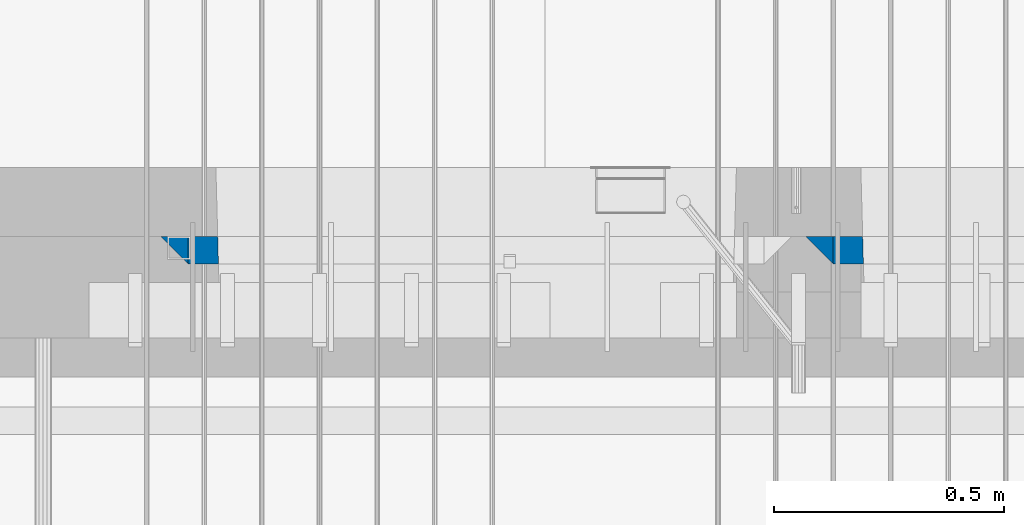
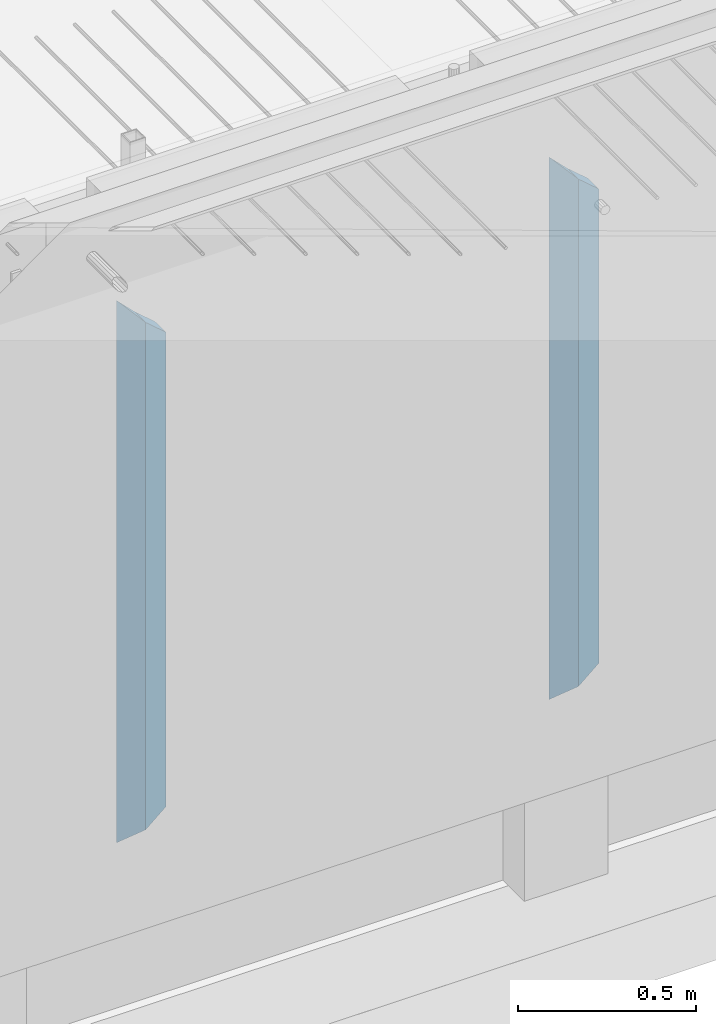
# One storey, part 3 of 325: 4 columns, 1 element without a shape of its own.
"""IFC2X3 building model written with IfcOpenShell, lengths in millimetres."""

from ifc_helpers import new_model, si_unit, frame, origin_with_axes, place, context, subcontext, project, spatial, faceted_brep, material, type_object, element, aggregate, save


model = new_model("IFC2X3")

# Units and contexts
model_context = context("Model", 3, precision=1e-05, world=origin_with_axes())
body_context = subcontext(model_context, "Body", "Model", "MODEL_VIEW")
ifc_project = project(units=[si_unit("LENGTHUNIT", "METRE", prefix="MILLI"), si_unit("AREAUNIT", "SQUARE_METRE"), si_unit("VOLUMEUNIT", "CUBIC_METRE"), si_unit("MASSUNIT", "GRAM", prefix="KILO"), si_unit("TIMEUNIT", "SECOND"), si_unit("PLANEANGLEUNIT", "RADIAN"), si_unit("SOLIDANGLEUNIT", "STERADIAN"), si_unit("THERMODYNAMICTEMPERATUREUNIT", "DEGREE_CELSIUS"), si_unit("LUMINOUSINTENSITYUNIT", "LUMEN")], contexts=[model_context])

# Site, building, storey
site_placement = place(None, origin_with_axes())
site = spatial("IfcSite", under=ifc_project, at=site_placement, CompositionType="ELEMENT")
building_placement = place(site_placement, origin_with_axes())
building = spatial("IfcBuilding", under=site, at=building_placement, CompositionType="ELEMENT")
storey_placement = place(building_placement, origin_with_axes())
storey = spatial("IfcBuildingStorey", under=building, at=storey_placement, Name="1", CompositionType="ELEMENT", Elevation=0.0)

# Assembly, columns
assembly_placement = place(storey_placement, origin_with_axes())
assembly = element("IfcElementAssembly", 1, at=assembly_placement, inside=storey, AssemblyPlace="NOTDEFINED", PredefinedType="REINFORCEMENT_UNIT")
ifc_material_1 = material(Name="CONCRETE/C30/37")
column_type_1 = type_object("IfcColumnType", PredefinedType="NOTDEFINED")
column_1_placement = place(assembly_placement, frame((30704.9996552717, 7820.0, 82320.0), z_axis=(1.0, 0.0, 0.0), x_axis=(0.0, 0.0, 1.0)))
column_1 = element("IfcColumn", 2, at=column_1_placement, type_object=column_type_1, material=ifc_material_1, Name="SK", context=body_context, shape_type="Brep", body=[
    faceted_brep([(1795.00000000001, -30.0, 30.0), (1855.0, -30.0, -30.0), (1795.00000000001, 30.0, 30.0), (60.0000000000073, -30.0, 30.0), (0.0, -30.0, -30.0), (60.0000000000073, 30.0, 30.0)], [[[0, 1, 2]], [[1, 0, 3, 4]], [[2, 1, 4, 5]], [[0, 2, 5, 3]], [[5, 4, 3]]]),
])
ifc_material_2 = material(Name="CONCRETE/C35/45")
column_2_placement = place(assembly_placement, frame((29305.0000367414, 7820.0, 82320.0), z_axis=(1.0, 0.0, 0.0), x_axis=(0.0, 0.0, 1.0)))
column_2 = element("IfcColumn", 3, at=column_2_placement, type_object=column_type_1, material=ifc_material_2, Name="SK", context=body_context, shape_type="Brep", body=[
    faceted_brep([(1795.00000000001, -30.0, 30.0), (1855.0, -30.0, -30.0), (1795.00000000001, 30.0, 30.0), (60.0000000000073, -30.0, 30.0), (0.0, -30.0, -30.0), (60.0000000000073, 30.0, 30.0)], [[[0, 1, 2]], [[1, 0, 3, 4]], [[2, 1, 4, 5]], [[0, 2, 5, 3]], [[5, 4, 3]]]),
])
column_type_2 = type_object("IfcColumnType", PredefinedType="NOTDEFINED")
column_3_placement = place(assembly_placement, frame((30769.9996552717, 7820.0, 82380.0), z_axis=(1.0, 0.0, 0.0), x_axis=(0.0, 0.0, 1.0)))
column_3 = element("IfcColumn", 4, at=column_3_placement, type_object=column_type_2, material=ifc_material_2, Name="SK", context=body_context, shape_type="Brep", body=[
    faceted_brep([(1678.70787161513, 29.999999998452, 30.6741497967687), (1680.09783300469, -29.999999998452, 29.0525281752307), (1735.0, -30.0, -35.0), (1735.0, 30.0, -35.0), (56.29212838487, 29.999999998452, 30.6741497967687), (54.9021669952926, -29.999999998452, 29.0525281752307), (0.0, -30.0, -35.0), (0.0, 30.0, -35.0)], [[[0, 1, 2, 3]], [[1, 0, 4, 5]], [[2, 1, 5, 6]], [[3, 2, 6, 7]], [[0, 3, 7, 4]], [[4, 7, 6, 5]]]),
])
column_4_placement = place(assembly_placement, frame((29370.0000367414, 7820.0, 82380.0), z_axis=(1.0, 0.0, 0.0), x_axis=(0.0, 0.0, 1.0)))
column_4 = element("IfcColumn", 5, at=column_4_placement, type_object=column_type_2, material=ifc_material_2, Name="SK", context=body_context, shape_type="Brep", body=[
    faceted_brep([(1735.0, -30.0, -35.0), (1735.0, 30.0, -35.0), (1678.70623674487, 30.0, 30.6760571454033), (1680.09619813452, -30.0, 29.0544355237798), (56.2937632551329, 29.9999988381387, 30.6760571454033), (54.9038019193104, -29.9999988381387, 29.0544355865859), (0.0, -30.0, -35.0), (0.0, 30.0, -35.0)], [[[0, 1, 2, 3]], [[3, 2, 4, 5]], [[0, 3, 5, 6]], [[1, 0, 6, 7]], [[2, 1, 7, 4]], [[5, 4, 7, 6]]]),
])
aggregate(assembly, [column_1, column_3, column_2, column_4])

save(model, "model.ifc")
